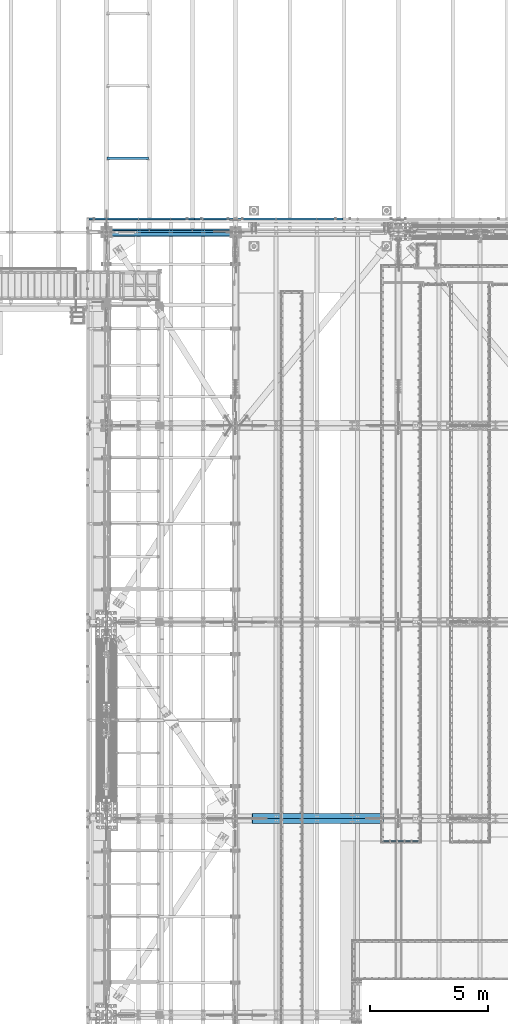
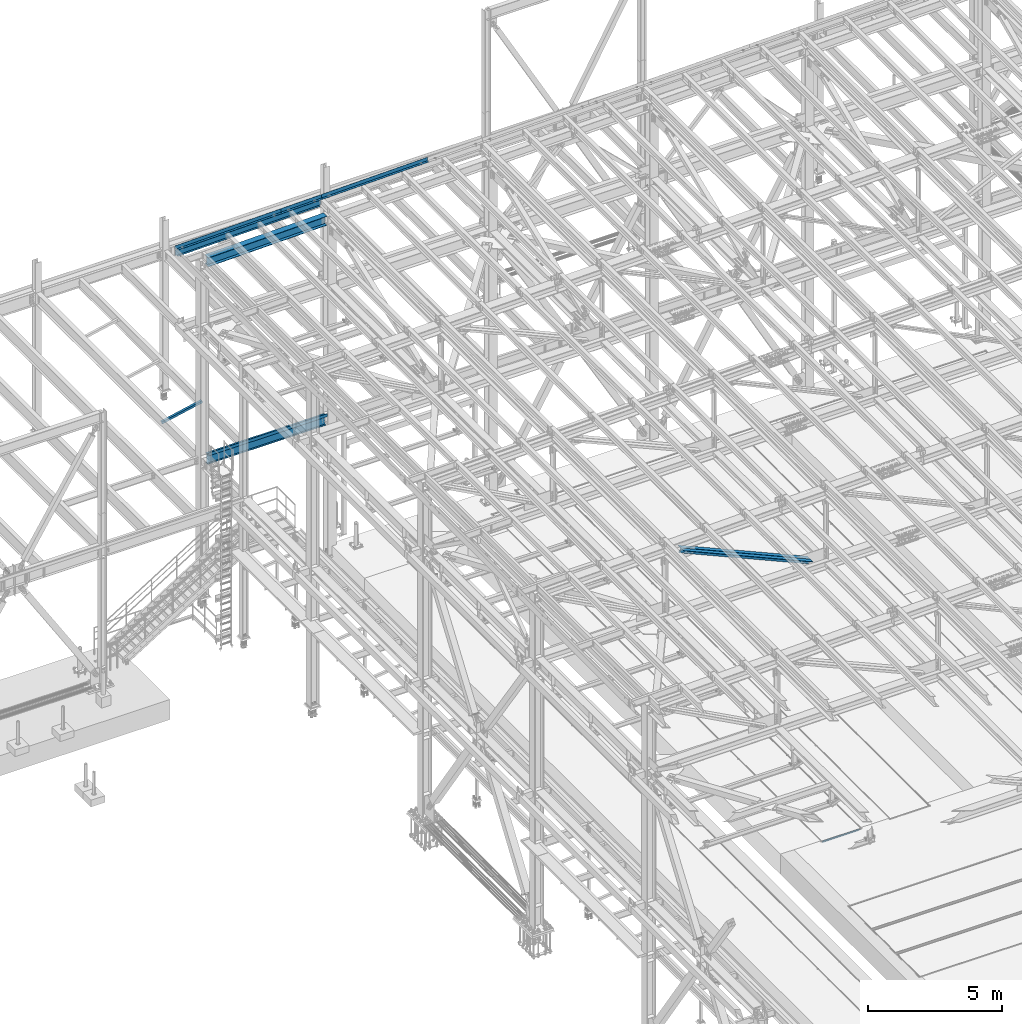
# One storey, part 1889 of 3843: 9 beams, 2 members, 8 elements without a shape of their own.
"""IFC2X3 building model written with IfcOpenShell, lengths in millimetres."""

import ifcopenshell
import ifcopenshell.guid

model = None  # the IFC model being written
_history = None  # IfcOwnerHistory: only IFC2X3 demands one
_inside = {}  # id of a spatial element -> (the spatial element, [elements in it])
_under = {}  # id of a project, library or spatial element -> (it, [spatial elements below it])
_declared = {}  # id of a project -> (the project, [libraries it declares])
_typed = {}  # id of a type object -> (the type object, [elements of that type])
_made_of = {}  # id of a material, layer set ... -> (it, [elements and type objects made of it])


def new_model(schema):
    """Start an empty IFC model of exactly this schema.

    Asked for "IFC4X3", IfcOpenShell would pick the latest addendum, in which some entities
    have other attributes; the version numbers below select the first issue.
    IFC2X3 requires an IfcOwnerHistory on every rooted entity: one is made here for all.
    """
    global model, _history
    if schema == "IFC4X3":
        model = ifcopenshell.file(schema_version=(4, 3, 0, 0))
    else:
        model = ifcopenshell.file(schema=schema)
    _inside.clear()
    _under.clear()
    _declared.clear()
    _typed.clear()
    _made_of.clear()
    _history = None
    if model.schema == "IFC2X3":
        org = make("IfcOrganization", Name="unknown")
        user = make(
            "IfcPersonAndOrganization",
            ThePerson=make("IfcPerson", FamilyName="unknown"),
            TheOrganization=org,
        )
        app = make(
            "IfcApplication",
            ApplicationDeveloper=org,
            Version="unknown",
            ApplicationFullName="unknown",
            ApplicationIdentifier="unknown",
        )
        _history = make(
            "IfcOwnerHistory",
            OwningUser=user,
            OwningApplication=app,
            ChangeAction="ADDED",
            CreationDate=0,
        )
    return model


def make(cls, **values):
    """One entity of the class cls with the attributes given. An attribute that is None is left unset."""
    return model.create_entity(
        cls, **{name: value for name, value in values.items() if value is not None}
    )


def rooted(cls, **values):
    """An entity with a GlobalId (a new one), such as an element, a storey or a relation."""
    return make(cls, GlobalId=ifcopenshell.guid.new(), OwnerHistory=_history, **values)


def si_unit(unit_type, name, prefix=None):
    """IfcSIUnit, for example si_unit("LENGTHUNIT", "METRE", prefix="MILLI")."""
    return make("IfcSIUnit", UnitType=unit_type, Prefix=prefix, Name=name)


def assignment(units):
    """IfcUnitAssignment: the units of a project."""
    return None if units is None else make("IfcUnitAssignment", Units=units)


def point(xyz):
    """IfcCartesianPoint."""
    return None if xyz is None else make("IfcCartesianPoint", Coordinates=xyz)


def direction(xyz):
    """IfcDirection."""
    return None if xyz is None else make("IfcDirection", DirectionRatios=xyz)


def frame(location, z_axis=None, x_axis=None):
    """IfcAxis2Placement3D, a coordinate frame: its origin and axes. An axis left out is left unset."""
    return make(
        "IfcAxis2Placement3D",
        Location=point(location),
        Axis=direction(z_axis),
        RefDirection=direction(x_axis),
    )


def origin_with_axes():
    """The frame at (0, 0, 0) with the z axis (0, 0, 1) and the x axis (1, 0, 0) written out."""
    return frame((0.0, 0.0, 0.0), z_axis=(0.0, 0.0, 1.0), x_axis=(1.0, 0.0, 0.0))


def place(relative_to, where):
    """IfcLocalPlacement: puts the frame where relative to a parent placement (None: the world)."""
    return make(
        "IfcLocalPlacement", PlacementRelTo=relative_to, RelativePlacement=where
    )


def context(
    kind, dimensions, precision=None, world=None, true_north=None, identifier=None
):
    """IfcGeometricRepresentationContext, for example the 3D "Model" context."""
    return make(
        "IfcGeometricRepresentationContext",
        ContextIdentifier=identifier,
        ContextType=kind,
        CoordinateSpaceDimension=dimensions,
        Precision=precision,
        WorldCoordinateSystem=world,
        TrueNorth=true_north,
    )


def subcontext(parent, identifier, kind, view, scale=None):
    """IfcGeometricRepresentationSubContext, for example "Body" below "Model"."""
    return make(
        "IfcGeometricRepresentationSubContext",
        ContextIdentifier=identifier,
        ContextType=kind,
        ParentContext=parent,
        TargetScale=scale,
        TargetView=view,
    )


def project(units=None, contexts=None):
    """IfcProject with its units and contexts."""
    return rooted(
        "IfcProject",
        Name="project",
        RepresentationContexts=contexts,
        UnitsInContext=assignment(units),
    )


def spatial(cls, under=None, at=None, **own):
    """A site, building, storey or space (cls), placed at a placement, below another one or the project."""
    s = rooted(cls, ObjectPlacement=at, **own)
    if under is not None:
        _under.setdefault(under.id(), (under, []))[1].append(s)
    return s


def faces_of(points, faces, orient=None, outer=None):
    """IfcFace entities. A face is a list of loops; a loop is a list of indices into points, from 0.

    orient and outer hold one flag for each loop. By default every Orientation is true, the
    first loop of a face is its IfcFaceOuterBound and the others are IfcFaceBound.
    """
    made = []
    for i, loops in enumerate(faces):
        bounds = []
        for j, loop in enumerate(loops):
            is_outer = j == 0 if outer is None else outer[i][j]
            bounds.append(
                make(
                    "IfcFaceOuterBound" if is_outer else "IfcFaceBound",
                    Bound=make("IfcPolyLoop", Polygon=[points[k] for k in loop]),
                    Orientation=True if orient is None else orient[i][j],
                )
            )
        made.append(make("IfcFace", Bounds=bounds))
    return made


def faceted_brep(points, faces, orient=None, outer=None, voids=None):
    """IfcFacetedBrep: a solid bounded by flat faces; with voids (closed shells), ...WithVoids."""
    shared = [point(p) for p in points]
    hull = make("IfcClosedShell", CfsFaces=faces_of(shared, faces, orient, outer))
    if voids is None:
        return make("IfcFacetedBrep", Outer=hull)
    return make(
        "IfcFacetedBrepWithVoids",
        Outer=hull,
        Voids=[
            make(cls, CfsFaces=faces_of(shared, fs, o, b)) for cls, fs, o, b in voids
        ],
    )


def shape(context_of_items, identifier, shape_type, items):
    """IfcShapeRepresentation: the items that make up one representation, for example the "Body"."""
    return make(
        "IfcShapeRepresentation",
        ContextOfItems=context_of_items,
        RepresentationIdentifier=identifier,
        RepresentationType=shape_type,
        Items=items,
    )


def material(Name=None, Category=None):
    """IfcMaterial."""
    return make("IfcMaterial", Name=Name, Category=Category)


def made_of(thing, what):
    """Note that an element or type object is made of a material, layer set ...; save() writes the relation."""
    if what is not None:
        _made_of.setdefault(what.id(), (what, []))[1].append(thing)
    return thing


def type_object(cls, material=None, **own):
    """A type object (cls), such as IfcWallType, which elements share."""
    return made_of(rooted(cls, **own), material)


def element(
    cls,
    number,
    at=None,
    inside=None,
    cuts=None,
    type_object=None,
    material=None,
    context=None,
    identifier="Body",
    shape_type=None,
    held_by="IfcProductDefinitionShape",
    body=None,
    shapes=None,
    **own,
):
    """One element of the class cls, such as IfcWall. Its Tag is "e" and its number.

    at: its placement. inside: the storey or other place that contains it. cuts: it is an
    opening in that element (IfcRelVoidsElement). A single representation is given by context,
    identifier, shape_type and body (its items); several are given by shapes. held_by: the class
    of the entity that holds the representations. save() writes the other relations.
    """
    e = rooted(cls, Tag="e%d" % number, ObjectPlacement=at, **own)
    if body is not None:
        shapes = [shape(context, identifier, shape_type, body)]
    if shapes is not None:
        e.Representation = make(held_by, Representations=shapes)
    if inside is not None:
        _inside.setdefault(inside.id(), (inside, []))[1].append(e)
    if cuts is not None:
        rooted(
            "IfcRelVoidsElement", RelatingBuildingElement=cuts, RelatedOpeningElement=e
        )
    if type_object is not None:
        _typed.setdefault(type_object.id(), (type_object, []))[1].append(e)
    return made_of(e, material)


def aggregate(whole, parts):
    """IfcRelAggregates: a whole, such as a stair, and the parts it consists of."""
    return rooted("IfcRelAggregates", RelatingObject=whole, RelatedObjects=parts)


def save(model, path):
    """Write the relations noted so far, then the file.

    IfcRelAggregates (storeys below a building ...), IfcRelContainedInSpatialStructure (elements
    in a storey), IfcRelDefinesByType, IfcRelAssociatesMaterial and IfcRelDeclares: one each for
    every whole, place, type object, material and project.
    """
    for whole, parts in _under.values():
        aggregate(whole, parts)
    for where, things in _inside.values():
        rooted(
            "IfcRelContainedInSpatialStructure",
            RelatedElements=things,
            RelatingStructure=where,
        )
    for kind, things in _typed.values():
        rooted("IfcRelDefinesByType", RelatedObjects=things, RelatingType=kind)
    for what, things in _made_of.values():
        rooted("IfcRelAssociatesMaterial", RelatedObjects=things, RelatingMaterial=what)
    for by, libraries in _declared.values():
        rooted("IfcRelDeclares", RelatingContext=by, RelatedDefinitions=libraries)
    model.write(path)


model = new_model("IFC2X3")

# Units and contexts
model_context = context("Model", 3, precision=1e-05, world=origin_with_axes())
body_context = subcontext(model_context, "Body", "Model", "MODEL_VIEW")
ifc_project = project(units=[si_unit("LENGTHUNIT", "METRE", prefix="MILLI"), si_unit("AREAUNIT", "SQUARE_METRE"), si_unit("VOLUMEUNIT", "CUBIC_METRE"), si_unit("MASSUNIT", "GRAM", prefix="KILO"), si_unit("TIMEUNIT", "SECOND"), si_unit("PLANEANGLEUNIT", "RADIAN"), si_unit("SOLIDANGLEUNIT", "STERADIAN"), si_unit("THERMODYNAMICTEMPERATUREUNIT", "DEGREE_CELSIUS"), si_unit("LUMINOUSINTENSITYUNIT", "LUMEN")], contexts=[model_context])

# Site, building, storey
site_placement = place(None, origin_with_axes())
site = spatial("IfcSite", under=ifc_project, at=site_placement, CompositionType="ELEMENT")
building_placement = place(site_placement, origin_with_axes())
building = spatial("IfcBuilding", under=site, at=building_placement, Name="Undefined", CompositionType="ELEMENT")
storey_placement = place(building_placement, origin_with_axes())
storey = spatial("IfcBuildingStorey", under=building, at=storey_placement, Name="Undefined", CompositionType="ELEMENT", Elevation=0.0)

# Assembly, beam
assembly_1_placement = place(storey_placement, origin_with_axes())
assembly_1 = element("IfcElementAssembly", 1, at=assembly_1_placement, inside=storey, Name="EMBED_ANGLE", AssemblyPlace="NOTDEFINED", PredefinedType="RIGID_FRAME")
ifc_material_1 = material(Name="STEEL/A36")
beam_type_1 = type_object("IfcBeamType", Name="L3-1/2X3-1/2X5/16", PredefinedType="NOTDEFINED")
beam_1_placement = place(assembly_1_placement, frame((48254.4116205071, 66281.4270224609, 30410.15), z_axis=(0.0, -1.0, 0.0), x_axis=(1.0, 0.0, 0.0)))
beam_1 = element("IfcBeam", 2, at=beam_1_placement, type_object=beam_type_1, material=ifc_material_1, Name="EMBED_ANGLE", ObjectType="L3-1/2X3-1/2X5/16", context=body_context, shape_type="Brep", body=[
    faceted_brep([(88.900303773109, 44.4500000000007, -44.4500000004336), (0.000309352857584599, 44.4500000000007, 44.4500000000116), (1701.80041569857, 44.4500000000007, 44.4499999912659), (1612.90041489631, 44.4500000000007, -44.4500000082771), (0.000309352857584599, 36.5125000000007, 44.4500000000116), (1701.80041569857, 36.5125000000007, 44.4499999912659), (80.9628042713011, 36.5125000000007, -36.51250000039), (1620.83791496794, 36.5125000000007, -36.5125000083208), (80.9628042713011, -44.4500000000007, -36.51250000039), (1620.83791496794, -44.4500000000007, -36.5125000083208), (88.900303773109, -44.4500000000007, -44.4500000004336), (1612.90041489631, -44.4500000000007, -44.4500000082771)], [[[0, 1, 2, 3]], [[1, 4, 5, 2]], [[4, 6, 7, 5]], [[6, 8, 9, 7]], [[8, 10, 11, 9]], [[10, 0, 3, 11]], [[5, 7, 9, 11, 3, 2]], [[10, 8, 6, 4, 1, 0]]]),
])
aggregate(assembly_1, [beam_1])

assembly_2_placement = place(storey_placement, origin_with_axes())
assembly_2 = element("IfcElementAssembly", 3, at=assembly_2_placement, inside=storey, Name="CHANNEL", AssemblyPlace="NOTDEFINED", PredefinedType="RIGID_FRAME")
ifc_material_2 = material(Name="STEEL/A572-50")
beam_type_2 = type_object("IfcBeamType", Name="C12X20.7", PredefinedType="NOTDEFINED")
beam_2_placement = place(assembly_2_placement, frame((35741.0235798256, 92786.1999999738, 45559.495069808), z_axis=(-0.0211520980073474, 0.0, 0.999776269347241), x_axis=(0.999776270257024, 0.0, 0.0211520550054619)))
beam_2 = element("IfcBeam", 4, at=beam_2_placement, type_object=beam_type_2, material=ifc_material_2, Name="CHANNEL", ObjectType="C12X20.7", context=body_context, shape_type="Brep", body=[
    faceted_brep([(20.6374999136679, 30.1625000000058, -126.999999999352), (20.6374999136679, 38.1000000000058, -126.999999999352), (77.7875001037028, 38.1000000000058, -126.999999999302), (77.7875001037028, 30.1625000000058, -126.999999999302), (82.6475796217346, 38.1000000000058, -127.966729921885), (82.6475796217346, 30.1625000000058, -127.966729921885), (86.7677560898665, 38.1000000000058, -130.719743822337), (86.7677560898665, 30.1625000000058, -130.719743822337), (89.5207699903331, 38.1000000000058, -134.839920290469), (89.5207699903403, 30.1625000000058, -134.674927499684), (90.4874999129242, 1.14757858682424e-06, -139.699999808494), (90.4874999129242, 38.1000000000058, -139.699999808494), (90.4874999129315, 38.1000000000058, -152.399999999659), (90.4874999129388, -38.1000000000058, -152.39999980729), (90.4874999129315, -38.1000000000058, -146.047459999667), (6221.00785836641, -38.1000000000058, 146.047460006012), (6221.0078583664, -38.1000000000058, 152.400000005997), (90.4874999126405, -38.1000000000058, 152.39999980975), (90.4874999126478, -38.1000000000058, 146.047459999863), (6221.0078583664, 38.1000000000058, 152.400000005997), (90.4874999126478, 38.1000000000058, 152.399999999849), (77.7875001034699, 30.1625000000058, 126.999999999338), (77.7875001034699, 38.1000000000058, 126.999999999338), (20.6374999136751, 38.1000000000058, 126.999999999272), (20.6374999136751, 30.1625000000058, 126.999999999272), (82.6475796214872, 30.1625000000058, 127.966729921922), (82.6475796214872, 38.1000000000058, 127.966729921922), (86.7677560896191, 30.1625000000058, 130.719743822396), (86.7677560896191, 38.1000000000058, 130.719743822396), (89.5207699900784, 30.1625000000058, 134.674927499873), (89.5207699900784, 38.1000000000058, 134.839920290535), (90.487499912655, 1.14834983833134e-06, 139.699999808552), (90.487499912655, 38.1000000000058, 139.699999808552), (6221.974588289, 30.1625000000058, 134.674927506036), (6221.00785836641, 8.03440343588591e-07, 139.699999872166), (6221.00785836641, 38.1000000000058, 139.699999872166), (6221.974588289, 38.1000000000058, 134.839920354148), (6224.72760218947, 30.1625000000058, 130.719743886017), (6224.72760218947, 38.1000000000058, 130.719743886017), (6228.8477786576, 30.1625000000058, 127.966729985557), (6228.8477786576, 38.1000000000058, 127.966729985557), (6233.70785817563, 30.1625000000058, 127.000000062973), (6233.70785817563, 38.1000000000058, 127.000000062973), (6303.55742588337, 30.1625000000058, 127.000000063053), (6303.55737560392, 38.1000000000058, 127.000000063039), (6303.55742587067, 30.1625000000058, 114.299999943127), (6303.55742564011, 30.1625000000058, -116.300000055475), (6303.55742562941, 30.1625000000058, -126.999999935717), (6303.55737534998, 38.1000000000058, -126.999999935724), (6233.70785817589, 30.1625000000058, -126.999999935797), (6233.70785817589, 38.1000000000058, -126.999999935797), (6228.84777865787, 30.1625000000058, -127.966729858381), (6228.84777865787, 38.1000000000058, -127.966729858381), (6224.72760218974, 30.1625000000058, -130.719743758855), (6224.72760218974, 38.1000000000058, -130.719743758855), (6221.97458828928, 30.1625000000058, -134.674927493536), (6221.97458828928, 38.1000000000058, -134.839920226987), (6221.0078583667, 1.4916731743142e-06, -139.699999745018), (6221.0078583667, 38.1000000000058, -139.699999745018), (6221.00785836671, -38.1000000000058, -146.047459993511), (6221.00785836672, -38.1000000000058, -152.399999993504), (6221.00785836672, 38.1000000000058, -152.399999993504), (20.6374999136679, 30.1625000000058, -116.29999999846), (20.6374999136679, 30.1625000000058, 114.29999999782)], [[[0, 1, 2, 3]], [[3, 2, 4, 5]], [[5, 4, 6, 7]], [[7, 6, 8, 9]], [[10, 11, 12, 13, 14]], [[9, 8, 11, 10]], [[15, 16, 17, 18]], [[16, 19, 20, 17]], [[21, 22, 23, 24]], [[25, 26, 22, 21]], [[27, 28, 26, 25]], [[29, 30, 28, 27]], [[31, 32, 30, 29]], [[17, 20, 32, 31, 18]], [[29, 33, 34, 15, 18, 31]], [[16, 15, 34, 35, 19]], [[33, 36, 35, 34]], [[37, 38, 36, 33]], [[39, 40, 38, 37]], [[41, 42, 40, 39]], [[43, 44, 42, 41]], [[44, 43, 45, 46, 47, 48]], [[47, 49, 50, 48]], [[51, 52, 50, 49]], [[53, 54, 52, 51]], [[55, 56, 54, 53]], [[57, 58, 56, 55]], [[59, 60, 61, 58, 57]], [[60, 59, 14, 13]], [[61, 60, 13, 12]], [[6, 4, 2, 1, 23, 22, 26, 28, 30, 32, 20, 19, 35, 36, 38, 40, 42, 44, 48, 50, 52, 54, 56, 58, 61, 12, 11, 8]], [[62, 63, 24, 23, 1, 0]], [[55, 53, 51, 49, 47, 46, 45, 43, 41, 39, 37, 33, 29, 27, 25, 21, 24, 63, 62, 0, 3, 5, 7, 9]], [[59, 57, 55, 9, 10, 14]]]),
])

assembly_3_placement = place(storey_placement, origin_with_axes())
assembly_3 = element("IfcElementAssembly", 5, at=assembly_3_placement, inside=storey, Name="ANGLE", AssemblyPlace="NOTDEFINED", PredefinedType="RIGID_FRAME")
beam_type_3 = type_object("IfcBeamType", Name="L4X4X3/8", PredefinedType="NOTDEFINED")
beam_3_placement = place(assembly_3_placement, frame((38364.4744366695, 95351.6, 36361.1915884738), z_axis=(0.0, 1.0, 0.0), x_axis=(-0.978512037964654, 0.0, -0.206189697992554)))
beam_3 = element("IfcBeam", 6, at=beam_3_placement, type_object=beam_type_3, material=ifc_material_2, Name="ANGLE", ObjectType="L4X4X3/8", context=body_context, shape_type="Brep", body=[
    faceted_brep([(0.0, 50.8000000000029, -50.8000000000029), (0.0, 50.8000000000029, 50.8000000000029), (1786.21921067611, 50.7999999987005, 50.8000000000029), (1786.21921067611, 50.7999999987005, -50.8000000000029), (0.0, 41.2750000000015, 50.8000000000029), (1786.2192106761, 41.27499999867, 50.8000000000029), (0.0, 41.2749999999942, -41.2750000000015), (1786.2192106761, 41.27499999867, -41.2749999999942), (0.0, -50.8000000000029, -41.2750000000015), (1786.21921067603, -50.8000000016073, -41.2749999999942), (0.0, -50.8000000000029, -50.8000000000029), (1786.21921067603, -50.8000000016073, -50.8000000000029)], [[[0, 1, 2, 3]], [[1, 4, 5, 2]], [[4, 6, 7, 5]], [[6, 8, 9, 7]], [[8, 10, 11, 9]], [[10, 0, 3, 11]], [[5, 7, 9, 11, 3, 2]], [[10, 8, 6, 4, 1, 0]]]),
])
aggregate(assembly_3, [beam_3])

# Beam
beam_type_4 = type_object("IfcBeamType", PredefinedType="NOTDEFINED")
beam_4_placement = place(assembly_2_placement, frame((41185.6077127508, 92722.6999831924, 45830.2950332614), z_axis=(0.999776270257024, 0.0, 0.0211520550054619), x_axis=(0.0, 1.0, 0.0)))
beam_4 = element("IfcBeam", 7, at=beam_4_placement, type_object=beam_type_4, material=ifc_material_1, Name="BENT_PLATE", context=body_context, shape_type="Brep", body=[
    faceted_brep([(6.54836185276508e-10, 5.76037564314902e-08, -870.74399999858), (-8.14907252788544e-10, 3.1749999991298, -867.569000035313), (95.2499985450559, 3.17500004378962, -867.569000035692), (98.4249985152856, 1.03755155578256e-07, -870.743999998958), (95.2499984796596, 161.925001510885, -867.569000036528), (98.4249984485796, 161.925001512231, -870.743999999358), (95.2499985462346, 3.17500004553585, 870.743999998223), (95.2499984783644, 161.925001515156, 870.743999997831), (2.12457962334156e-09, -3.17500000086147, -870.743999998573), (8.00355337560177e-10, -3.17499999912252, 870.743999998602), (-2.13913153856993e-09, 3.17500000086875, 870.743999998602), (101.599998547725, -3.17499995322578, -870.743999998973), (101.599998548903, -3.17499995147955, 870.743999998209), (101.59999847837, 161.925001517862, 870.743999997816), (101.599998479651, 161.925001513591, -870.743999999373)], [[[0, 1, 2, 3]], [[3, 2, 4, 5]], [[6, 7, 4, 2]], [[8, 9, 10, 1, 0]], [[10, 6, 2, 1]], [[9, 8, 11, 12]], [[6, 10, 9, 12, 13, 7]], [[12, 11, 14, 13]], [[14, 11, 8, 0, 3, 5]], [[7, 13, 14, 5, 4]]]),
])

# Assembly, beam
assembly_4_placement = place(storey_placement, origin_with_axes())
assembly_4 = element("IfcElementAssembly", 8, at=assembly_4_placement, inside=storey, Name="CHANNEL", AssemblyPlace="NOTDEFINED", PredefinedType="RIGID_FRAME")
beam_5_placement = place(assembly_4_placement, frame((44341.6454511775, 92722.6999533715, 45897.0667917161), z_axis=(0.999776270257024, 0.0, 0.0211520550054619), x_axis=(0.0, 1.0, 0.0)))
beam_5 = element("IfcBeam", 9, at=beam_5_placement, type_object=beam_type_4, material=ifc_material_1, Name="BENT_PLATE", context=body_context, shape_type="Brep", body=[
    faceted_brep([(0.0, 0.0, -2286.0), (3.49245965480804e-10, 3.17499999771098, -2282.82500002157), (95.2499986609328, 3.17500004237809, -2282.82500002194), (98.4249986544455, 9.08548827283084e-08, -2285.99999999666), (95.249998597661, 161.925001390824, -2282.82500002276), (98.4249985899223, 161.92500139217, -2285.99999999706), (95.2499986633193, 3.17500004695466, 2285.99999999594), (95.2499985934701, 161.925001402509, 2285.99999999556), (5.82076609134674e-11, -3.17499999999563, -2286.0), (5.82076609134674e-11, -3.17499999999563, 2286.0), (-4.36557456851006e-11, 3.17499999998836, 2286.0), (101.599998662903, -3.17499995464459, -2285.99999999667), (101.600001545667, -3.17499906016019, 2285.99999999734), (101.599998593476, 161.925001405216, 2285.99999999553), (101.599998596852, 161.925001394004, -2285.99999999707)], [[[0, 1, 2, 3]], [[3, 2, 4, 5]], [[6, 7, 4, 2]], [[8, 9, 10, 1, 0]], [[10, 6, 2, 1]], [[9, 8, 11, 12]], [[6, 10, 9, 12, 13, 7]], [[12, 11, 14, 13]], [[14, 11, 8, 0, 3, 5]], [[7, 13, 14, 5, 4]]]),
])
aggregate(assembly_4, [beam_5])

# Beam
beam_6_placement = place(assembly_2_placement, frame((38029.5699731465, 92722.6999533709, 45763.5232747907), z_axis=(0.999776270257024, 0.0, 0.0211520550054619), x_axis=(0.0, 1.0, 0.0)))
beam_6 = element("IfcBeam", 10, at=beam_6_placement, type_object=beam_type_4, material=ifc_material_1, Name="BENT_PLATE", context=body_context, shape_type="Brep", body=[
    faceted_brep([(101.600000642575, 3.17500004378962, -2190.75000213859), (95.2499986609619, 3.17500004247267, -2190.75000200525), (95.2499986602343, 3.17500004237081, -2285.99999999666), (101.600001600964, 3.175000001851, -2286.0), (101.600000645354, -3.17499995617982, -2190.75000213858), (0.0, -3.17500000000291, -2190.75000000003), (2.61934474110603e-10, 3.17499999781285, -2190.750000005), (101.599998593476, 161.925001405216, 2285.99999999553), (101.599998596852, 161.925001394004, -2285.99999999707), (95.2499985968607, 161.925001391297, -2285.99999999705), (95.2499985934701, 161.925001402509, 2285.99999999556), (95.2499986633193, 3.17500004695466, 2285.99999999594), (-4.36557456851006e-11, 3.17499999998836, 2286.0), (5.82076609134674e-11, -3.17499999999563, 2286.0), (101.600001545667, -3.17499906016019, 2285.99999999734)], [[[0, 1, 2, 3]], [[4, 5, 6, 1, 0]], [[7, 8, 9, 10]], [[11, 12, 13, 14, 7, 10]], [[3, 8, 7, 14, 4, 0]], [[9, 8, 3, 2]], [[11, 10, 9, 2, 1]], [[12, 11, 1, 6]], [[13, 12, 6, 5]], [[14, 13, 5, 4]]]),
])

aggregate(assembly_2, [beam_4, beam_2, beam_6])

# Assembly, member
assembly_5_placement = place(storey_placement, origin_with_axes())
assembly_5 = element("IfcElementAssembly", 11, at=assembly_5_placement, inside=storey, Name="ANGLE", AssemblyPlace="NOTDEFINED", PredefinedType="RIGID_FRAME")
member_type = type_object("IfcMemberType", Name="L8X8X1/2", PredefinedType="NOTDEFINED")
member_1_placement = place(assembly_5_placement, frame((42062.4, 67383.025, 45368.1367754596), z_axis=(-0.403776103914738, 0.0, -0.914857834806827), x_axis=(0.914857834806826, 0.0, -0.40377610391474)))
member_1 = element("IfcMember", 12, at=member_1_placement, type_object=member_type, material=ifc_material_2, Name="ANGLE", ObjectType="L8X8X1/2", context=body_context, shape_type="Brep", body=[
    faceted_brep([(737.653608944533, 101.600000000006, -101.600000001607), (737.653608944533, 101.600000000006, 101.599999999031), (6832.47900084817, 101.600000000006, 101.599999988495), (6832.47900084817, 101.600000000006, -101.600000012142), (737.653608944533, 88.8999999999942, 101.599999999031), (6832.47900084817, 88.8999999999942, 101.599999988495), (737.653608944529, 88.8999999999942, -88.9000000015658), (6832.47900084817, 88.8999999999942, -88.9000000121014), (737.653608944529, -101.600000000006, -88.9000000015658), (6832.47900084817, -101.600000000006, -88.9000000121014), (737.653608944533, -101.600000000006, -101.600000001607), (6832.47900084817, -101.600000000006, -101.600000012142)], [[[0, 1, 2, 3]], [[1, 4, 5, 2]], [[4, 6, 7, 5]], [[6, 8, 9, 7]], [[8, 10, 11, 9]], [[10, 0, 3, 11]], [[5, 7, 9, 11, 3, 2]], [[10, 8, 6, 4, 1, 0]]]),
])
aggregate(assembly_5, [member_1])

assembly_6_placement = place(storey_placement, origin_with_axes())
assembly_6 = element("IfcElementAssembly", 13, at=assembly_6_placement, inside=storey, Name="ANGLE", AssemblyPlace="NOTDEFINED", PredefinedType="RIGID_FRAME")
member_2_placement = place(assembly_6_placement, frame((48996.5999982877, 67160.775, 42307.7003300748), z_axis=(-0.403776103914738, 0.0, -0.914857834806827), x_axis=(-0.914857834806825, 0.0, 0.403776103914741)))
member_2 = element("IfcMember", 14, at=member_2_placement, type_object=member_type, material=ifc_material_2, Name="ANGLE", ObjectType="L8X8X1/2", context=body_context, shape_type="Brep", body=[
    faceted_brep([(747.059299946508, 101.600000000006, -101.599999999024), (747.059299946504, 101.600000000006, 101.600000001607), (6841.88469185015, 101.600000000006, 101.600000012157), (6841.88469185015, 101.600000000006, -101.599999988481), (747.059299946504, 88.8999999999942, 101.600000001607), (6841.88469185015, 88.8999999999942, 101.600000012157), (747.059299946504, 88.8999999999942, -88.8999999989828), (6841.88469185015, 88.8999999999942, -88.89999998844), (747.059299946504, -101.600000000006, -88.8999999989828), (6841.88469185015, -101.600000000006, -88.89999998844), (747.059299946508, -101.600000000006, -101.599999999024), (6841.88469185015, -101.600000000006, -101.599999988481)], [[[0, 1, 2, 3]], [[1, 4, 5, 2]], [[4, 6, 7, 5]], [[6, 8, 9, 7]], [[8, 10, 11, 9]], [[10, 0, 3, 11]], [[5, 7, 9, 11, 3, 2]], [[10, 8, 6, 4, 1, 0]]]),
])
aggregate(assembly_6, [member_2])

# Assembly, beam
assembly_7_placement = place(storey_placement, origin_with_axes())
assembly_7 = element("IfcElementAssembly", 15, at=assembly_7_placement, inside=storey, Name="BEAM", AssemblyPlace="NOTDEFINED", PredefinedType="RIGID_FRAME")
beam_type_5 = type_object("IfcBeamType", PredefinedType="NOTDEFINED")
beam_7_placement = place(assembly_7_placement, frame((39316.025, 92189.3, 36439.475), z_axis=(-1.0, 0.0, 0.0), x_axis=(0.0, -1.0, 0.0)))
beam_7 = element("IfcBeam", 16, at=beam_7_placement, type_object=beam_type_5, material=ifc_material_1, Name="BENT_PLATE", context=body_context, shape_type="Brep", body=[
    faceted_brep([(0.0, -3.17500000000291, -2549.525), (0.0, -3.17500000000291, 2549.525), (0.0, 3.17500000000291, 2549.525), (0.0, 3.17500000000291, -2549.525), (146.049993896479, 3.17500000000291, 2549.525), (146.049993896479, 3.17500000000291, -2549.525), (152.399993896484, -3.17500000000291, -2549.525), (152.399993896484, -3.17500000000291, 2549.525), (146.049993896479, 136.524996948239, 2549.525), (146.049993896479, 136.524996948239, -2549.525), (152.399993896484, 136.524996948239, 2549.525), (152.399993896484, 136.524996948239, -2549.525)], [[[0, 1, 2, 3]], [[3, 2, 4, 5]], [[1, 0, 6, 7]], [[5, 4, 8, 9]], [[4, 2, 1, 7, 10, 8]], [[7, 6, 11, 10]], [[6, 0, 3, 5, 9, 11]], [[10, 11, 9, 8]]]),
])

assembly_8_placement = place(storey_placement, origin_with_axes())
assembly_8 = element("IfcElementAssembly", 17, at=assembly_8_placement, inside=storey, Name="BEAM", AssemblyPlace="NOTDEFINED", PredefinedType="RIGID_FRAME")
ifc_material_3 = material(Name="STEEL/A992")
beam_type_6 = type_object("IfcBeamType", Name="W16X67", PredefinedType="NOTDEFINED")
beam_8_placement = place(assembly_8_placement, frame((36580.3988432745, 92214.7, 45210.4590275866), z_axis=(-0.0211520980073474, 0.0, 0.999776269347241), x_axis=(0.999776270257024, 0.0, 0.0211520550054619)))
beam_8 = element("IfcBeam", 18, at=beam_8_placement, type_object=beam_type_6, material=ifc_material_3, Name="BEAM", ObjectType="W16X67", context=body_context, shape_type="Brep", body=[
    faceted_brep([(181.742975470595, -130.174999999999, -207.962499999499), (181.742975470595, 130.174999999999, -207.962499999499), (5281.93404407822, 130.174999999999, -207.962499994363), (5281.93404407822, -130.174999999999, -207.962499994363), (182.112426639622, -130.174999999999, -190.499999999527), (182.112426639622, -4.76250000000073, -190.499999999527), (190.173179417936, -4.76250000000073, 190.499999999862), (190.173179417936, -130.174999999999, 190.499999999862), (190.542630586948, -130.174999999999, 207.962499999841), (190.542630586948, 130.174999999999, 207.962499999841), (190.173179417936, 130.174999999999, 190.499999999862), (190.173179417936, 4.76250000000073, 190.499999999862), (182.112426639622, 4.76250000000073, -190.499999999527), (182.112426639622, 130.174999999999, -190.499999999527), (5282.30349524722, -130.174999999999, -190.499999994383), (5282.30349524722, -4.76250000000073, -190.499999994383), (5283.04215288762, -4.76249999999709, -155.586565885467), (5289.78924910998, -4.76249999999709, 163.322068509886), (5290.36424802549, -4.76250000000073, 190.500000005006), (5290.36424802549, -130.174999999999, 190.500000005006), (5290.7336991945, -130.174999999999, 207.962500004978), (5290.7336991945, 130.174999999999, 207.962500004978), (5290.36424802549, 130.174999999999, 190.500000005006), (5290.36424802549, 4.76250000000073, 190.500000005006), (5282.30349524722, 4.76250000000073, -190.499999994383), (5282.30349524722, 130.174999999999, -190.499999994383)], [[[0, 1, 2, 3]], [[0, 4, 5, 6, 7, 8, 9, 10, 11, 12, 13, 1]], [[5, 4, 14, 15]], [[6, 5, 15, 16, 17, 18]], [[7, 6, 18, 19]], [[8, 7, 19, 20]], [[9, 8, 20, 21]], [[10, 9, 21, 22]], [[11, 10, 22, 23]], [[12, 11, 23, 24]], [[13, 12, 24, 25]], [[1, 13, 25, 2]], [[24, 23, 22, 21, 20, 19, 18, 17, 16, 15, 14, 3, 2, 25]], [[4, 0, 3, 14]]]),
])
aggregate(assembly_8, [beam_8])

# Beam
beam_type_7 = type_object("IfcBeamType", Name="W18X40", PredefinedType="NOTDEFINED")
beam_9_placement = place(assembly_7_placement, frame((36576.0, 92214.7, 36209.2875), z_axis=(0.0, 0.0, 1.0), x_axis=(1.0, 0.0, 0.0)))
beam_9 = element("IfcBeam", 19, at=beam_9_placement, type_object=beam_type_7, material=ifc_material_3, Name="BEAM", ObjectType="W18X40", context=body_context, shape_type="Brep", body=[
    faceted_brep([(190.5, -76.1999999999971, -227.012499999997), (190.5, 76.1999999999971, -227.012499999997), (5289.55, 76.1999999999971, -227.012499999997), (5289.55, -76.1999999999971, -227.012499999997), (190.5, -76.1999999999971, -214.3125), (190.5, -3.96875, -214.3125), (190.5, -3.96875, 214.3125), (190.5, -76.1999999999971, 214.3125), (190.5, -76.1999999999971, 227.012499999997), (190.5, 76.1999999999971, 227.012499999997), (190.5, 76.1999999999971, 214.3125), (190.5, 3.96875, 214.3125), (190.5, 3.96875, -214.3125), (190.5, 76.1999999999971, -214.3125), (5289.55, -76.1999999999971, -214.3125), (5289.55, -3.96875, -214.3125), (5289.55, -3.96875, 214.3125), (5289.55, -76.1999999999971, 214.3125), (5289.55, -76.1999999999971, 227.012499999997), (5289.55, 76.1999999999971, 227.012499999997), (5289.55, 76.1999999999971, 214.3125), (5289.55, 3.96875, 214.3125), (5289.55, 3.96875, 196.002499999995), (5289.55, 3.96875, -122.977500000001), (5289.55, 3.96875, -214.3125), (5289.55, 76.1999999999971, -214.3125)], [[[0, 1, 2, 3]], [[0, 4, 5, 6, 7, 8, 9, 10, 11, 12, 13, 1]], [[5, 4, 14, 15]], [[6, 5, 15, 16]], [[7, 6, 16, 17]], [[8, 7, 17, 18]], [[9, 8, 18, 19]], [[10, 9, 19, 20]], [[11, 10, 20, 21]], [[12, 11, 21, 22, 23, 24]], [[13, 12, 24, 25]], [[1, 13, 25, 2]], [[24, 23, 22, 21, 20, 19, 18, 17, 16, 15, 14, 3, 2, 25]], [[4, 0, 3, 14]]]),
])

aggregate(assembly_7, [beam_7, beam_9])

save(model, "model.ifc")
